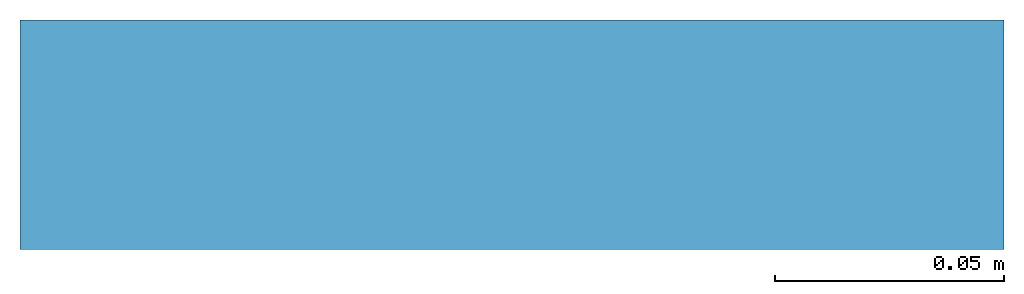
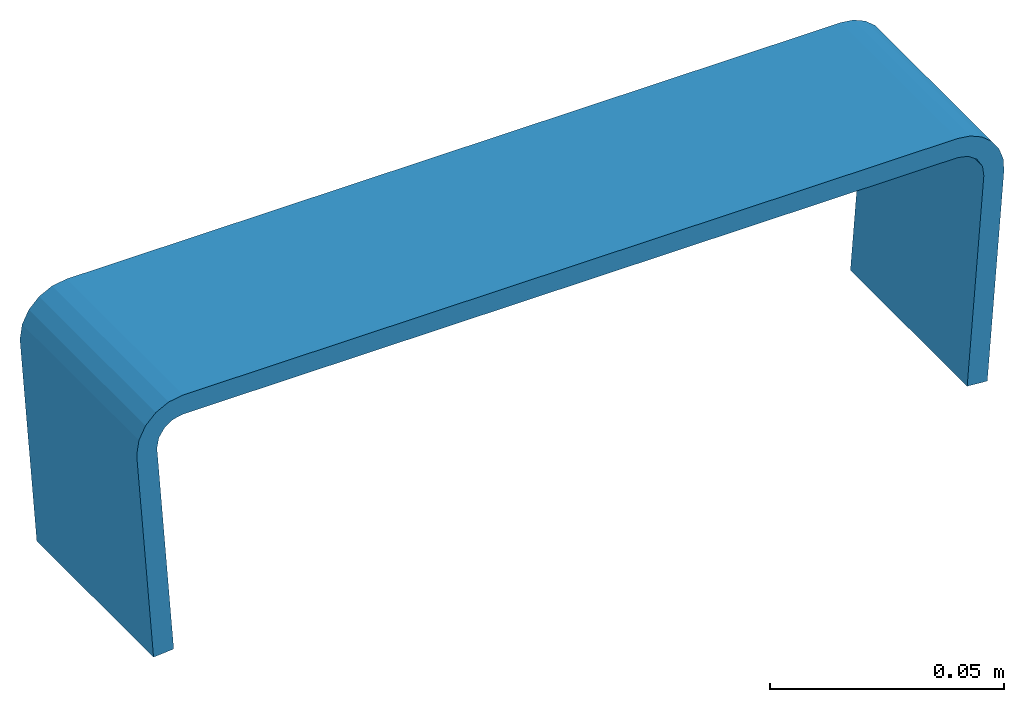
# One storey: 1 beam, 1 element without a shape of its own.
"""IFC2X3 building model written with IfcOpenShell, lengths in metres."""

from ifc_helpers import new_model, si_unit, direction, frame, origin_with_axes, place, context, project, spatial, faceted_brep, source, transform, mapped, material, element, aggregate, save


model = new_model("IFC2X3")

# Units and contexts
model_context = context("Model", 3, precision=1e-06, world=origin_with_axes(), true_north=direction((0.0, 1.0, 0.0)))
ifc_project = project(units=[si_unit("LENGTHUNIT", "METRE"), si_unit("AREAUNIT", "SQUARE_METRE"), si_unit("VOLUMEUNIT", "CUBIC_METRE")], contexts=[model_context])

# Site, building, storey
site_placement = place(None, origin_with_axes())
site = spatial("IfcSite", under=ifc_project, at=site_placement, CompositionType="ELEMENT")
building_placement = place(site_placement, origin_with_axes())
building = spatial("IfcBuilding", under=site, at=building_placement, Name="Default Building", CompositionType="ELEMENT")
storey_placement = place(building_placement, origin_with_axes())
storey = spatial("IfcBuildingStorey", under=building, at=storey_placement, Name="Default Storey", CompositionType="ELEMENT", Elevation=0.0)

# Assembly, beam
assembly_placement = place(storey_placement, origin_with_axes())
assembly = element("IfcElementAssembly", 1, at=assembly_placement, inside=storey, Name="3", ObjectType="3", AssemblyPlace="NOTDEFINED", PredefinedType="NOTDEFINED")
ifc_material = material(Name="Steel")
shared_shape = source(origin_with_axes(), model_context, "Body", "Brep", [
    faceted_brep([(-0.09760292619466782, 0.03210984170436859, 0.0), (-0.0975753590464592, 0.03131406381726265, 0.0), (-0.09760292619466782, 0.03210984170436859, 0.05000000074505806), (-0.09760292619466782, 0.03210984170436859, 0.05000000074505806), (-0.0975753590464592, 0.03131406381726265, 0.0), (-0.0975753590464592, 0.03131406381726265, 0.05000000074505806), (-0.0926029309630394, 0.03210984170436859, 0.05000000074505806), (-0.0926029309630394, 0.03210984170436859, 0.0), (-0.09210345894098282, 0.034608565270900726, 0.05000000074505806), (-0.09210345894098282, 0.034608565270900726, 0.05000000074505806), (-0.0926029309630394, 0.03210984170436859, 0.0), (-0.09210345894098282, 0.034608565270900726, 0.0), (-0.09210345894098282, 0.034608565270900726, 0.05000000074505806), (-0.09210345894098282, 0.034608565270900726, 0.0), (-0.09068181365728378, 0.03672328218817711, 0.05000000074505806), (-0.09068181365728378, 0.03672328218817711, 0.05000000074505806), (-0.09210345894098282, 0.034608565270900726, 0.0), (-0.09068181365728378, 0.03672328218817711, 0.0), (-0.09068181365728378, 0.03672328218817711, 0.05000000074505806), (-0.09068181365728378, 0.03672328218817711, 0.0), (-0.08855646848678589, 0.038128990679979324, 0.05000000074505806), (-0.08855646848678589, 0.038128990679979324, 0.05000000074505806), (-0.09068181365728378, 0.03672328218817711, 0.0), (-0.08855646848678589, 0.038128990679979324, 0.0), (-0.08855646848678589, 0.038128990679979324, 0.05000000074505806), (-0.08855646848678589, 0.038128990679979324, 0.0), (-0.08605405688285828, 0.03860965743660927, 0.05000000074505806), (-0.08605405688285828, 0.03860965743660927, 0.05000000074505806), (-0.08855646848678589, 0.038128990679979324, 0.0), (-0.08605405688285828, 0.03860965743660927, 0.0), (-0.08855646848678589, 0.038128990679979324, 0.05000000074505806), (-0.08605405688285828, 0.03860965743660927, 0.05000000074505806), (-0.0860164687037468, 0.04360951483249664, 0.05000000074505806), (-0.0975753590464592, 0.03131406381726265, 0.05000000074505806), (-0.09258734434843063, 0.0316600538790226, 0.05000000074505806), (-0.09760292619466782, 0.03210984170436859, 0.05000000074505806), (-0.09760292619466782, 0.03210984170436859, 0.05000000074505806), (-0.09258734434843063, 0.0316600538790226, 0.05000000074505806), (-0.0926029309630394, 0.03210984170436859, 0.05000000074505806), (-0.09760292619466782, 0.03210984170436859, 0.05000000074505806), (-0.0926029309630394, 0.03210984170436859, 0.05000000074505806), (-0.09703472256660461, 0.035679981112480164, 0.05000000074505806), (-0.09703472256660461, 0.035679981112480164, 0.05000000074505806), (-0.0926029309630394, 0.03210984170436859, 0.05000000074505806), (-0.09210345894098282, 0.034608565270900726, 0.05000000074505806), (-0.09703472256660461, 0.035679981112480164, 0.05000000074505806), (-0.09210345894098282, 0.034608565270900726, 0.05000000074505806), (-0.09538625180721283, 0.0388973206281662, 0.05000000074505806), (-0.09538625180721283, 0.0388973206281662, 0.05000000074505806), (-0.09210345894098282, 0.034608565270900726, 0.05000000074505806), (-0.09068181365728378, 0.03672328218817711, 0.05000000074505806), (-0.09538625180721283, 0.0388973206281662, 0.05000000074505806), (-0.09068181365728378, 0.03672328218817711, 0.05000000074505806), (-0.0928204208612442, 0.04144393652677536, 0.05000000074505806), (-0.0928204208612442, 0.04144393652677536, 0.05000000074505806), (-0.09068181365728378, 0.03672328218817711, 0.05000000074505806), (-0.08855646848678589, 0.038128990679979324, 0.05000000074505806), (-0.0928204208612442, 0.04144393652677536, 0.05000000074505806), (-0.08855646848678589, 0.038128990679979324, 0.05000000074505806), (-0.08959077298641205, 0.04306816682219505, 0.05000000074505806), (-0.08959077298641205, 0.04306816682219505, 0.05000000074505806), (-0.08855646848678589, 0.038128990679979324, 0.05000000074505806), (-0.0860164687037468, 0.04360951483249664, 0.05000000074505806), (-0.0975753590464592, 0.03131406381726265, 0.05000000074505806), (-0.09385653585195541, -0.022298987954854965, 0.05000000074505806), (-0.09258734434843063, 0.0316600538790226, 0.05000000074505806), (-0.09258734434843063, 0.0316600538790226, 0.05000000074505806), (-0.09385653585195541, -0.022298987954854965, 0.05000000074505806), (-0.08886852115392685, -0.021952997893095016, 0.05000000074505806), (-0.09258734434843063, 0.0316600538790226, 0.0), (-0.0975753590464592, 0.03131406381726265, 0.0), (-0.0926029309630394, 0.03210984170436859, 0.0), (-0.0926029309630394, 0.03210984170436859, 0.0), (-0.0975753590464592, 0.03131406381726265, 0.0), (-0.09760292619466782, 0.03210984170436859, 0.0), (-0.0926029309630394, 0.03210984170436859, 0.0), (-0.09760292619466782, 0.03210984170436859, 0.0), (-0.09210345894098282, 0.034608565270900726, 0.0), (-0.09210345894098282, 0.034608565270900726, 0.0), (-0.09760292619466782, 0.03210984170436859, 0.0), (-0.09703472256660461, 0.035679981112480164, 0.0), (-0.09210345894098282, 0.034608565270900726, 0.0), (-0.09703472256660461, 0.035679981112480164, 0.0), (-0.09068181365728378, 0.03672328218817711, 0.0), (-0.0860164687037468, 0.04360951483249664, 0.0), (-0.08605405688285828, 0.03860965743660927, 0.0), (-0.08959077298641205, 0.04306816682219505, 0.0), (-0.08959077298641205, 0.04306816682219505, 0.0), (-0.08605405688285828, 0.03860965743660927, 0.0), (-0.08855646848678589, 0.038128990679979324, 0.0), (-0.08959077298641205, 0.04306816682219505, 0.0), (-0.08855646848678589, 0.038128990679979324, 0.0), (-0.0928204208612442, 0.04144393652677536, 0.0), (-0.0928204208612442, 0.04144393652677536, 0.0), (-0.08855646848678589, 0.038128990679979324, 0.0), (-0.09068181365728378, 0.03672328218817711, 0.0), (-0.0928204208612442, 0.04144393652677536, 0.0), (-0.09068181365728378, 0.03672328218817711, 0.0), (-0.09538625180721283, 0.0388973206281662, 0.0), (-0.09538625180721283, 0.0388973206281662, 0.0), (-0.09068181365728378, 0.03672328218817711, 0.0), (-0.09703472256660461, 0.035679981112480164, 0.0), (-0.0860164687037468, 0.04360951483249664, 0.0), (0.1054176315665245, 0.04217017441987991, 0.0), (-0.08605405688285828, 0.03860965743660927, 0.0), (-0.08605405688285828, 0.03860965743660927, 0.0), (0.1054176315665245, 0.04217017441987991, 0.0), (0.10538003593683243, 0.03717031702399254, 0.0), (0.10797811299562454, 0.03660713881254196, 0.05000000074505806), (0.11013343185186386, 0.03505093976855278, 0.05000000074505806), (0.11382748186588287, 0.03842050954699516, 0.05000000074505806), (0.11382748186588287, 0.03842050954699516, 0.05000000074505806), (0.11013343185186386, 0.03505093976855278, 0.05000000074505806), (0.11561063677072525, 0.03582632169127464, 0.05000000074505806), (0.11561063677072525, 0.03582632169127464, 0.05000000074505806), (0.11013343185186386, 0.03505093976855278, 0.05000000074505806), (0.11148547381162643, 0.03276202455163002, 0.05000000074505806), (0.11561063677072525, 0.03582632169127464, 0.05000000074505806), (0.11148547381162643, 0.03276202455163002, 0.05000000074505806), (0.11662355810403824, 0.032845813781023026, 0.05000000074505806), (0.11662355810403824, 0.032845813781023026, 0.05000000074505806), (0.11148547381162643, 0.03276202455163002, 0.05000000074505806), (0.11180809140205383, 0.030123259872198105, 0.05000000074505806), (0.11662355810403824, 0.032845813781023026, 0.05000000074505806), (0.11180809140205383, 0.030123259872198105, 0.05000000074505806), (0.11679033935070038, 0.029702305793762207, 0.05000000074505806), (0.1054176315665245, 0.04217017441987991, 0.05000000074505806), (0.10538003593683243, 0.03717031702399254, 0.05000000074505806), (0.1085326075553894, 0.041715897619724274, 0.05000000074505806), (0.1085326075553894, 0.041715897619724274, 0.05000000074505806), (0.10538003593683243, 0.03717031702399254, 0.05000000074505806), (0.10797811299562454, 0.03660713881254196, 0.05000000074505806), (0.1085326075553894, 0.041715897619724274, 0.05000000074505806), (0.10797811299562454, 0.03660713881254196, 0.05000000074505806), (0.11140770465135574, 0.04043399170041084, 0.05000000074505806), (0.11140770465135574, 0.04043399170041084, 0.05000000074505806), (0.10797811299562454, 0.03660713881254196, 0.05000000074505806), (0.11382748186588287, 0.03842050954699516, 0.05000000074505806), (0.1054176315665245, 0.04217017441987991, 0.05000000074505806), (-0.0860164687037468, 0.04360951483249664, 0.05000000074505806), (0.10538003593683243, 0.03717031702399254, 0.05000000074505806), (0.10538003593683243, 0.03717031702399254, 0.05000000074505806), (-0.0860164687037468, 0.04360951483249664, 0.05000000074505806), (-0.08605405688285828, 0.03860965743660927, 0.05000000074505806), (0.11148547381162643, 0.03276202455163002, 0.0), (0.11013343185186386, 0.03505093976855278, 0.0), (0.11382748186588287, 0.03842050954699516, 0.0), (0.11382748186588287, 0.03842050954699516, 0.0), (0.11013343185186386, 0.03505093976855278, 0.0), (0.11140770465135574, 0.04043399170041084, 0.0), (0.11140770465135574, 0.04043399170041084, 0.0), (0.11013343185186386, 0.03505093976855278, 0.0), (0.10797811299562454, 0.03660713881254196, 0.0), (0.11140770465135574, 0.04043399170041084, 0.0), (0.10797811299562454, 0.03660713881254196, 0.0), (0.1085326075553894, 0.041715897619724274, 0.0), (0.1085326075553894, 0.041715897619724274, 0.0), (0.10797811299562454, 0.03660713881254196, 0.0), (0.10538003593683243, 0.03717031702399254, 0.0), (0.1085326075553894, 0.041715897619724274, 0.0), (0.10538003593683243, 0.03717031702399254, 0.0), (0.1054176315665245, 0.04217017441987991, 0.0), (0.11679033935070038, 0.029702305793762207, 0.0), (0.11180809140205383, 0.030123259872198105, 0.0), (0.11662355810403824, 0.032845813781023026, 0.0), (0.11662355810403824, 0.032845813781023026, 0.0), (0.11180809140205383, 0.030123259872198105, 0.0), (0.11148547381162643, 0.03276202455163002, 0.0), (0.11662355810403824, 0.032845813781023026, 0.0), (0.11148547381162643, 0.03276202455163002, 0.0), (0.11561063677072525, 0.03582632169127464, 0.0), (0.11561063677072525, 0.03582632169127464, 0.0), (0.11148547381162643, 0.03276202455163002, 0.0), (0.11382748186588287, 0.03842050954699516, 0.0), (0.11679033935070038, 0.029702305793762207, 0.0), (0.11226577311754227, -0.023848766461014748, 0.0), (0.11180809140205383, 0.030123259872198105, 0.0), (0.11180809140205383, 0.030123259872198105, 0.0), (0.11226577311754227, -0.023848766461014748, 0.0), (0.10728352516889572, -0.02342781238257885, 0.0), (-0.09385653585195541, -0.022298987954854965, 0.05000000074505806), (-0.0975753590464592, 0.03131406381726265, 0.05000000074505806), (-0.09385653585195541, -0.022298987954854965, 0.0), (-0.09385653585195541, -0.022298987954854965, 0.0), (-0.0975753590464592, 0.03131406381726265, 0.05000000074505806), (-0.0975753590464592, 0.03131406381726265, 0.0), (-0.08886852115392685, -0.021952997893095016, 0.05000000074505806), (-0.09385653585195541, -0.022298987954854965, 0.05000000074505806), (-0.08886852115392685, -0.021952997893095016, 0.0), (-0.08886852115392685, -0.021952997893095016, 0.0), (-0.09385653585195541, -0.022298987954854965, 0.05000000074505806), (-0.09385653585195541, -0.022298987954854965, 0.0), (-0.09258734434843063, 0.0316600538790226, 0.05000000074505806), (-0.08886852115392685, -0.021952997893095016, 0.05000000074505806), (-0.09258734434843063, 0.0316600538790226, 0.0), (-0.09258734434843063, 0.0316600538790226, 0.0), (-0.08886852115392685, -0.021952997893095016, 0.05000000074505806), (-0.08886852115392685, -0.021952997893095016, 0.0), (-0.09258734434843063, 0.0316600538790226, 0.05000000074505806), (-0.09258734434843063, 0.0316600538790226, 0.0), (-0.0926029309630394, 0.03210984170436859, 0.05000000074505806), (-0.0926029309630394, 0.03210984170436859, 0.05000000074505806), (-0.09258734434843063, 0.0316600538790226, 0.0), (-0.0926029309630394, 0.03210984170436859, 0.0), (0.10538003593683243, 0.03717031702399254, 0.05000000074505806), (-0.08605405688285828, 0.03860965743660927, 0.05000000074505806), (0.10538003593683243, 0.03717031702399254, -2.7755575615628914e-17), (0.10538003593683243, 0.03717031702399254, -2.7755575615628914e-17), (-0.08605405688285828, 0.03860965743660927, 0.05000000074505806), (-0.08605405688285828, 0.03860965743660927, -2.7755575615628914e-17), (0.10538003593683243, 0.03717031702399254, 0.05000000074505806), (0.10538003593683243, 0.03717031702399254, 0.0), (0.10797811299562454, 0.03660713881254196, 0.05000000074505806), (0.10797811299562454, 0.03660713881254196, 0.05000000074505806), (0.10538003593683243, 0.03717031702399254, 0.0), (0.10797811299562454, 0.03660713881254196, 0.0), (0.10797811299562454, 0.03660713881254196, 0.05000000074505806), (0.10797811299562454, 0.03660713881254196, 0.0), (0.11013343185186386, 0.03505093976855278, 0.05000000074505806), (0.11013343185186386, 0.03505093976855278, 0.05000000074505806), (0.10797811299562454, 0.03660713881254196, 0.0), (0.11013343185186386, 0.03505093976855278, 0.0), (0.11013343185186386, 0.03505093976855278, 0.05000000074505806), (0.11013343185186386, 0.03505093976855278, 0.0), (0.11148547381162643, 0.03276202455163002, 0.05000000074505806), (0.11148547381162643, 0.03276202455163002, 0.05000000074505806), (0.11013343185186386, 0.03505093976855278, 0.0), (0.11148547381162643, 0.03276202455163002, 0.0), (0.11148547381162643, 0.03276202455163002, 0.05000000074505806), (0.11148547381162643, 0.03276202455163002, 0.0), (0.11180809140205383, 0.030123259872198105, 0.05000000074505806), (0.11180809140205383, 0.030123259872198105, 0.05000000074505806), (0.11148547381162643, 0.03276202455163002, 0.0), (0.11180809140205383, 0.030123259872198105, 0.0), (0.10728352516889572, -0.02342781238257885, 0.05000000074505806), (0.11180809140205383, 0.030123259872198105, 0.05000000074505806), (0.10728352516889572, -0.02342781238257885, -2.7755575615628914e-17), (0.10728352516889572, -0.02342781238257885, -2.7755575615628914e-17), (0.11180809140205383, 0.030123259872198105, 0.05000000074505806), (0.11180809140205383, 0.030123259872198105, -2.7755575615628914e-17), (0.11226577311754227, -0.023848766461014748, 0.05000000074505806), (0.10728352516889572, -0.02342781238257885, 0.05000000074505806), (0.11226577311754227, -0.023848766461014748, -2.7755575615628914e-17), (0.11226577311754227, -0.023848766461014748, -2.7755575615628914e-17), (0.10728352516889572, -0.02342781238257885, 0.05000000074505806), (0.10728352516889572, -0.02342781238257885, -2.7755575615628914e-17), (0.11679033935070038, 0.029702305793762207, 0.05000000074505806), (0.11226577311754227, -0.023848766461014748, 0.05000000074505806), (0.11679033935070038, 0.029702305793762207, -2.7755575615628914e-17), (0.11679033935070038, 0.029702305793762207, -2.7755575615628914e-17), (0.11226577311754227, -0.023848766461014748, 0.05000000074505806), (0.11226577311754227, -0.023848766461014748, -2.7755575615628914e-17), (0.11679033935070038, 0.029702305793762207, 0.05000000074505806), (0.11679033935070038, 0.029702305793762207, 0.0), (0.11662355810403824, 0.032845813781023026, 0.0), (0.11679033935070038, 0.029702305793762207, 0.05000000074505806), (0.11662355810403824, 0.032845813781023026, 0.0), (0.11662355810403824, 0.032845813781023026, 0.05000000074505806), (0.11662355810403824, 0.032845813781023026, 0.05000000074505806), (0.11662355810403824, 0.032845813781023026, 0.0), (0.11561063677072525, 0.03582632169127464, 0.0), (0.11662355810403824, 0.032845813781023026, 0.05000000074505806), (0.11561063677072525, 0.03582632169127464, 0.0), (0.11561063677072525, 0.03582632169127464, 0.05000000074505806), (0.11561063677072525, 0.03582632169127464, 0.05000000074505806), (0.11561063677072525, 0.03582632169127464, 0.0), (0.11382748186588287, 0.03842050954699516, 0.0), (0.11561063677072525, 0.03582632169127464, 0.05000000074505806), (0.11382748186588287, 0.03842050954699516, 0.0), (0.11382748186588287, 0.03842050954699516, 0.05000000074505806), (0.11382748186588287, 0.03842050954699516, 0.05000000074505806), (0.11382748186588287, 0.03842050954699516, 0.0), (0.11140770465135574, 0.04043399170041084, 0.0), (0.11382748186588287, 0.03842050954699516, 0.05000000074505806), (0.11140770465135574, 0.04043399170041084, 0.0), (0.11140770465135574, 0.04043399170041084, 0.05000000074505806), (0.11140770465135574, 0.04043399170041084, 0.05000000074505806), (0.11140770465135574, 0.04043399170041084, 0.0), (0.1085326075553894, 0.041715897619724274, 0.0), (0.11140770465135574, 0.04043399170041084, 0.05000000074505806), (0.1085326075553894, 0.041715897619724274, 0.0), (0.1085326075553894, 0.041715897619724274, 0.05000000074505806), (0.1085326075553894, 0.041715897619724274, 0.05000000074505806), (0.1085326075553894, 0.041715897619724274, 0.0), (0.1054176315665245, 0.04217017441987991, 0.0), (0.1085326075553894, 0.041715897619724274, 0.05000000074505806), (0.1054176315665245, 0.04217017441987991, 0.0), (0.1054176315665245, 0.04217017441987991, 0.05000000074505806), (-0.0860164687037468, 0.04360951483249664, 0.05000000074505806), (0.1054176315665245, 0.04217017441987991, 0.05000000074505806), (-0.0860164687037468, 0.04360951483249664, 0.0), (-0.0860164687037468, 0.04360951483249664, 0.0), (0.1054176315665245, 0.04217017441987991, 0.05000000074505806), (0.1054176315665245, 0.04217017441987991, 0.0), (-0.0860164687037468, 0.04360951483249664, 0.05000000074505806), (-0.0860164687037468, 0.04360951483249664, 0.0), (-0.08959077298641205, 0.04306816682219505, 0.0), (-0.0860164687037468, 0.04360951483249664, 0.05000000074505806), (-0.08959077298641205, 0.04306816682219505, 0.0), (-0.08959077298641205, 0.04306816682219505, 0.05000000074505806), (-0.08959077298641205, 0.04306816682219505, 0.05000000074505806), (-0.08959077298641205, 0.04306816682219505, 0.0), (-0.0928204208612442, 0.04144393652677536, 0.0), (-0.08959077298641205, 0.04306816682219505, 0.05000000074505806), (-0.0928204208612442, 0.04144393652677536, 0.0), (-0.0928204208612442, 0.04144393652677536, 0.05000000074505806), (-0.0928204208612442, 0.04144393652677536, 0.05000000074505806), (-0.0928204208612442, 0.04144393652677536, 0.0), (-0.09538625180721283, 0.0388973206281662, 0.0), (-0.0928204208612442, 0.04144393652677536, 0.05000000074505806), (-0.09538625180721283, 0.0388973206281662, 0.0), (-0.09538625180721283, 0.0388973206281662, 0.05000000074505806), (-0.09538625180721283, 0.0388973206281662, 0.05000000074505806), (-0.09538625180721283, 0.0388973206281662, 0.0), (-0.09703472256660461, 0.035679981112480164, 0.0), (-0.09538625180721283, 0.0388973206281662, 0.05000000074505806), (-0.09703472256660461, 0.035679981112480164, 0.0), (-0.09703472256660461, 0.035679981112480164, 0.05000000074505806), (-0.09703472256660461, 0.035679981112480164, 0.05000000074505806), (-0.09703472256660461, 0.035679981112480164, 0.0), (-0.09760292619466782, 0.03210984170436859, 0.0), (-0.09703472256660461, 0.035679981112480164, 0.05000000074505806), (-0.09760292619466782, 0.03210984170436859, 0.0), (-0.09760292619466782, 0.03210984170436859, 0.05000000074505806), (0.11180809140205383, 0.030123259872198105, 0.05000000074505806), (0.10728352516889572, -0.02342781238257885, 0.05000000074505806), (0.11679033935070038, 0.029702305793762207, 0.05000000074505806), (0.11679033935070038, 0.029702305793762207, 0.05000000074505806), (0.10728352516889572, -0.02342781238257885, 0.05000000074505806), (0.11226577311754227, -0.023848766461014748, 0.05000000074505806), (-0.09258734434843063, 0.0316600538790226, 0.0), (-0.08886852115392685, -0.021952997893095016, 0.0), (-0.0975753590464592, 0.03131406381726265, 0.0), (-0.0975753590464592, 0.03131406381726265, 0.0), (-0.08886852115392685, -0.021952997893095016, 0.0), (-0.09385653585195541, -0.022298987954854965, 0.0)], [[[0, 1, 2]], [[3, 4, 5]], [[6, 7, 8]], [[9, 10, 11]], [[12, 13, 14]], [[15, 16, 17]], [[18, 19, 20]], [[21, 22, 23]], [[24, 25, 26]], [[27, 28, 29]], [[30, 31, 32]], [[33, 34, 35]], [[36, 37, 38]], [[39, 40, 41]], [[42, 43, 44]], [[45, 46, 47]], [[48, 49, 50]], [[51, 52, 53]], [[54, 55, 56]], [[57, 58, 59]], [[60, 61, 62]], [[63, 64, 65]], [[66, 67, 68]], [[69, 70, 71]], [[72, 73, 74]], [[75, 76, 77]], [[78, 79, 80]], [[81, 82, 83]], [[84, 85, 86]], [[87, 88, 89]], [[90, 91, 92]], [[93, 94, 95]], [[96, 97, 98]], [[99, 100, 101]], [[102, 103, 104]], [[105, 106, 107]], [[108, 109, 110]], [[111, 112, 113]], [[114, 115, 116]], [[117, 118, 119]], [[120, 121, 122]], [[123, 124, 125]], [[126, 127, 128]], [[129, 130, 131]], [[132, 133, 134]], [[135, 136, 137]], [[138, 139, 140]], [[141, 142, 143]], [[144, 145, 146]], [[147, 148, 149]], [[150, 151, 152]], [[153, 154, 155]], [[156, 157, 158]], [[159, 160, 161]], [[162, 163, 164]], [[165, 166, 167]], [[168, 169, 170]], [[171, 172, 173]], [[174, 175, 176]], [[177, 178, 179]], [[180, 181, 182]], [[183, 184, 185]], [[186, 187, 188]], [[189, 190, 191]], [[192, 193, 194]], [[195, 196, 197]], [[198, 199, 200]], [[201, 202, 203]], [[204, 205, 206]], [[207, 208, 209]], [[210, 211, 212]], [[213, 214, 215]], [[216, 217, 218]], [[219, 220, 221]], [[222, 223, 224]], [[225, 226, 227]], [[228, 229, 230]], [[231, 232, 233]], [[234, 235, 236]], [[237, 238, 239]], [[240, 241, 242]], [[243, 244, 245]], [[246, 247, 248]], [[249, 250, 251]], [[252, 253, 254]], [[255, 256, 257]], [[258, 259, 260]], [[261, 262, 263]], [[264, 265, 266]], [[267, 268, 269]], [[270, 271, 272]], [[273, 274, 275]], [[276, 277, 278]], [[279, 280, 281]], [[282, 283, 284]], [[285, 286, 287]], [[288, 289, 290]], [[291, 292, 293]], [[294, 295, 296]], [[297, 298, 299]], [[300, 301, 302]], [[303, 304, 305]], [[306, 307, 308]], [[309, 310, 311]], [[312, 313, 314]], [[315, 316, 317]], [[318, 319, 320]], [[321, 322, 323]], [[324, 325, 326]], [[327, 328, 329]], [[330, 331, 332]], [[333, 334, 335]]]),
])
beam_placement = place(assembly_placement, frame((-0.10509469379740172, -0.04350839692040435, -0.007961567226792698), z_axis=(1.734723475976807e-18, -1.0000000000000002, -1.0191765336029867e-21), x_axis=(0.999971735517425, 1.734715813276078e-18, 0.007518521548084493)))
beam = element("IfcBeam", 2, at=beam_placement, material=ifc_material, Name="2", ObjectType="2", context=model_context, shape_type="MappedRepresentation", body=[
    mapped(shared_shape, transform((0.0, 0.0, 0.0), scale=1.0)),
])
aggregate(assembly, [beam])

save(model, "model.ifc")
